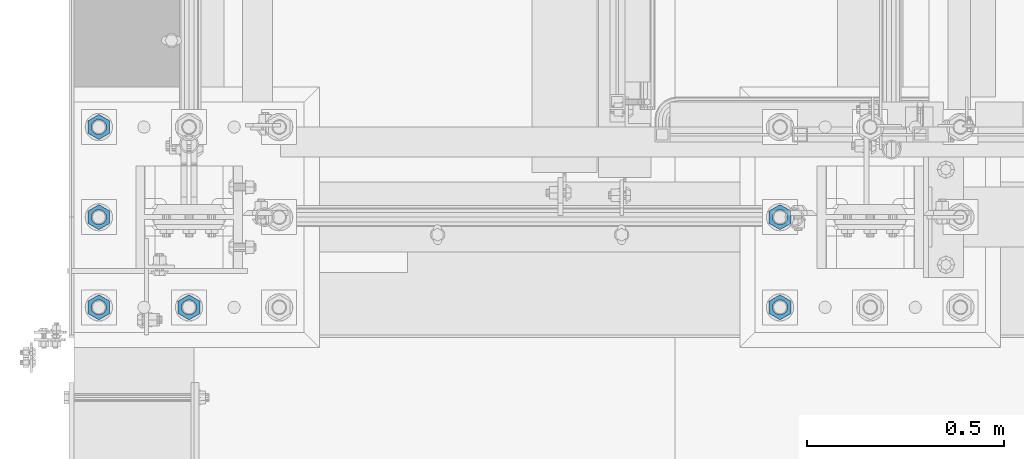
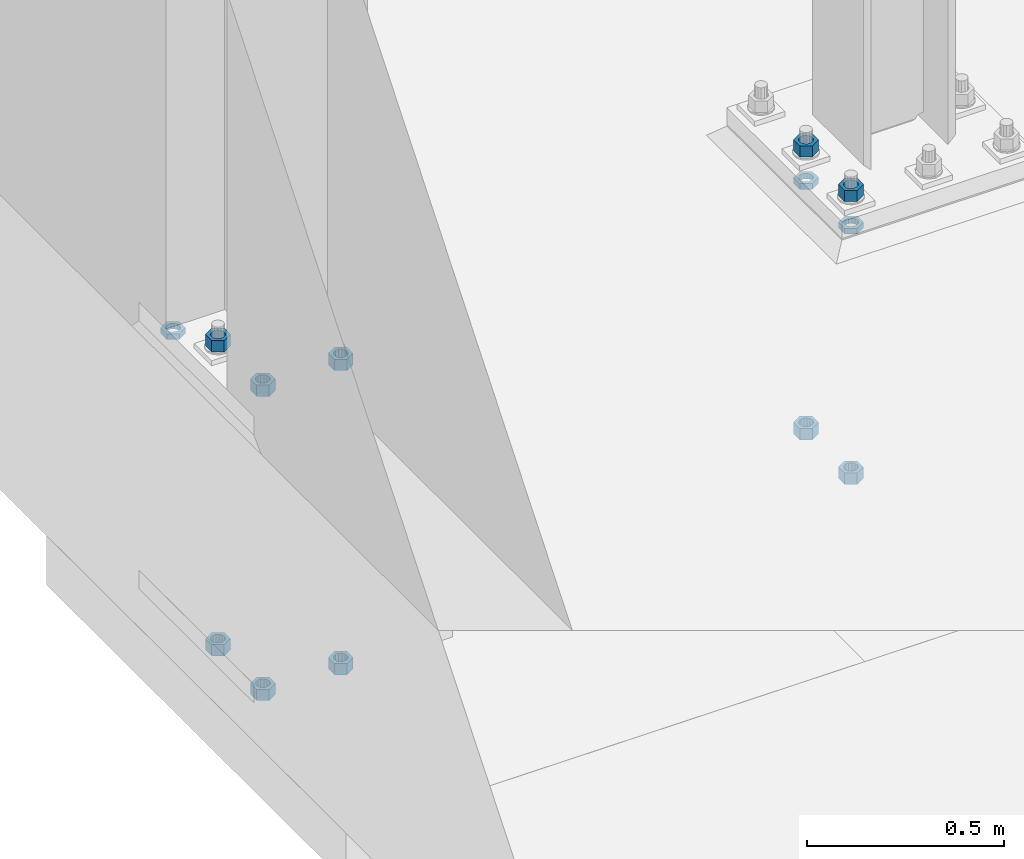
# One storey, part 1382 of 1876: 13 beams, 2 elements without a shape of their own.
"""IFC2X3 building model written with IfcOpenShell, lengths in millimetres."""

from ifc_helpers import new_model, si_unit, frame, origin_with_axes, place, context, subcontext, project, spatial, faceted_brep, material, type_object, element, aggregate, save


model = new_model("IFC2X3")

# Units and contexts
model_context = context("Model", 3, precision=1e-05, world=origin_with_axes())
body_context = subcontext(model_context, "Body", "Model", "MODEL_VIEW")
ifc_project = project(units=[si_unit("LENGTHUNIT", "METRE", prefix="MILLI"), si_unit("AREAUNIT", "SQUARE_METRE"), si_unit("VOLUMEUNIT", "CUBIC_METRE"), si_unit("MASSUNIT", "GRAM", prefix="KILO"), si_unit("TIMEUNIT", "SECOND"), si_unit("PLANEANGLEUNIT", "RADIAN"), si_unit("SOLIDANGLEUNIT", "STERADIAN"), si_unit("THERMODYNAMICTEMPERATUREUNIT", "DEGREE_CELSIUS"), si_unit("LUMINOUSINTENSITYUNIT", "LUMEN")], contexts=[model_context])

# Site, building, storey
site_placement = place(None, origin_with_axes())
site = spatial("IfcSite", under=ifc_project, at=site_placement, CompositionType="ELEMENT")
building_placement = place(site_placement, origin_with_axes())
building = spatial("IfcBuilding", under=site, at=building_placement, Name="Undefined", CompositionType="ELEMENT")
storey_placement = place(building_placement, origin_with_axes())
storey = spatial("IfcBuildingStorey", under=building, at=storey_placement, Name="Undefined", CompositionType="ELEMENT", Elevation=0.0)

# Assembly, beams
assembly_1_placement = place(storey_placement, origin_with_axes())
assembly_1 = element("IfcElementAssembly", 1, at=assembly_1_placement, inside=storey, Name="TEMPLATE", AssemblyPlace="NOTDEFINED", PredefinedType="RIGID_FRAME")
ifc_material = material(Name="STEEL/A563")
beam_type_1 = type_object("IfcBeamType", Name="1-3/8_DIA. HALF_NUT", PredefinedType="NOTDEFINED")
beam_1_placement = place(assembly_1_placement, frame((1498.6, -7112.0, 33.3375), z_axis=(1.0, 0.0, 0.0), x_axis=(0.0, 0.0, -1.0)))
beam_1 = element("IfcBeam", 2, at=beam_1_placement, type_object=beam_type_1, material=ifc_material, Name="NUT", ObjectType="1-3/8_DIA. HALF_NUT", context=body_context, shape_type="Brep", body=[
    faceted_brep([(0.0, -31.75, 0.0), (0.0, -15.8800001144409, -27.5), (17.4625, -15.8800001144409, -27.5), (17.4625, -31.75, 0.0), (0.0, 15.8800001144409, -27.5), (17.4625, 15.8800001144409, -27.5), (0.0, 31.75, 0.0), (17.4625, 31.75, 0.0), (0.0, 15.8800001144409, 27.5), (17.4625, 15.8800001144409, 27.5), (0.0, -15.8800001144409, 27.5), (17.4625, -15.8800001144409, 27.5), (0.0, 0.0, 19.0499999999993), (0.0, 8.2654848991624, 17.1634562461559), (17.4625, 8.2654848991624, 17.1634562461559), (17.4625, 0.0, 19.0499992370605), (0.0, 14.8938891445259, 11.8774802497237), (17.4625, 14.8938891445259, 11.8774802497237), (0.0, 18.5723759832526, 4.2390236220981), (17.4625, 18.5723759832526, 4.2390236220981), (0.0, 18.5723759832526, -4.2390236220981), (17.4625, 18.5723759832526, -4.2390236220981), (0.0, 14.8938891445259, -11.8774802497237), (17.4625, 14.8938891445259, -11.8774802497237), (0.0, 8.2654848991624, -17.1634562461568), (17.4625, 8.2654848991624, -17.1634562461568), (0.0, 0.0, -19.05), (17.4625, 0.0, -19.0499992370605), (0.0, -8.2654848991624, -17.1634562461559), (17.4625, -8.2654848991624, -17.1634562461559), (0.0, -14.8938891445259, -11.8774802497237), (17.4625, -14.8938891445259, -11.8774802497237), (0.0, -18.5723759832526, -4.2390236220981), (17.4625, -18.5723759832526, -4.2390236220981), (0.0, -18.5723759832526, 4.2390236220981), (17.4625, -18.5723759832526, 4.2390236220981), (0.0, -14.8938891445259, 11.8774802497237), (17.4625, -14.8938891445259, 11.8774802497237), (0.0, -8.2654848991624, 17.1634562461568), (17.4625, -8.2654848991624, 17.1634562461568)], [[[0, 1, 2, 3]], [[1, 4, 5, 2]], [[4, 6, 7, 5]], [[6, 8, 9, 7]], [[8, 10, 11, 9]], [[10, 0, 3, 11]], [[12, 13, 14, 15]], [[13, 16, 17, 14]], [[16, 18, 19, 17]], [[18, 20, 21, 19]], [[20, 22, 23, 21]], [[22, 24, 25, 23]], [[24, 26, 27, 25]], [[26, 28, 29, 27]], [[28, 30, 31, 29]], [[30, 32, 33, 31]], [[32, 34, 35, 33]], [[34, 36, 37, 35]], [[36, 38, 39, 37]], [[38, 12, 15, 39]], [[5, 7, 9, 11, 3, 2], [17, 19, 21, 23, 25, 27, 29, 31, 33, 35, 37, 39, 15, 14]], [[10, 8, 6, 4, 1, 0], [38, 36, 34, 32, 30, 28, 26, 24, 22, 20, 18, 16, 13, 12]]]),
])
beam_2_placement = place(assembly_1_placement, frame((1498.6, -7340.6, 33.3375), z_axis=(1.0, 0.0, 0.0), x_axis=(0.0, 0.0, -1.0)))
beam_2 = element("IfcBeam", 3, at=beam_2_placement, type_object=beam_type_1, material=ifc_material, Name="NUT", ObjectType="1-3/8_DIA. HALF_NUT", context=body_context, shape_type="Brep", body=[
    faceted_brep([(0.0, -31.75, 0.0), (0.0, -15.8800001144409, -27.5), (17.4625, -15.8800001144409, -27.5), (17.4625, -31.75, 0.0), (0.0, 15.8800001144409, -27.5), (17.4625, 15.8800001144409, -27.5), (0.0, 31.75, 0.0), (17.4625, 31.75, 0.0), (0.0, 15.8800001144409, 27.5), (17.4625, 15.8800001144409, 27.5), (0.0, -15.8800001144409, 27.5), (17.4625, -15.8800001144409, 27.5), (0.0, 0.0, 19.0499999999993), (0.0, 8.2654848991624, 17.1634562461559), (17.4625, 8.2654848991624, 17.1634562461559), (17.4625, 0.0, 19.0499992370605), (0.0, 14.8938891445259, 11.8774802497237), (17.4625, 14.8938891445259, 11.8774802497237), (0.0, 18.5723759832526, 4.2390236220981), (17.4625, 18.5723759832526, 4.2390236220981), (0.0, 18.5723759832526, -4.2390236220981), (17.4625, 18.5723759832526, -4.2390236220981), (0.0, 14.8938891445259, -11.8774802497237), (17.4625, 14.8938891445259, -11.8774802497237), (0.0, 8.2654848991624, -17.1634562461568), (17.4625, 8.2654848991624, -17.1634562461568), (0.0, 0.0, -19.05), (17.4625, 0.0, -19.0499992370605), (0.0, -8.2654848991624, -17.1634562461559), (17.4625, -8.2654848991624, -17.1634562461559), (0.0, -14.8938891445259, -11.8774802497237), (17.4625, -14.8938891445259, -11.8774802497237), (0.0, -18.5723759832526, -4.2390236220981), (17.4625, -18.5723759832526, -4.2390236220981), (0.0, -18.5723759832526, 4.2390236220981), (17.4625, -18.5723759832526, 4.2390236220981), (0.0, -14.8938891445259, 11.8774802497237), (17.4625, -14.8938891445259, 11.8774802497237), (0.0, -8.2654848991624, 17.1634562461568), (17.4625, -8.2654848991624, 17.1634562461568)], [[[0, 1, 2, 3]], [[1, 4, 5, 2]], [[4, 6, 7, 5]], [[6, 8, 9, 7]], [[8, 10, 11, 9]], [[10, 0, 3, 11]], [[12, 13, 14, 15]], [[13, 16, 17, 14]], [[16, 18, 19, 17]], [[18, 20, 21, 19]], [[20, 22, 23, 21]], [[22, 24, 25, 23]], [[24, 26, 27, 25]], [[26, 28, 29, 27]], [[28, 30, 31, 29]], [[30, 32, 33, 31]], [[32, 34, 35, 33]], [[34, 36, 37, 35]], [[36, 38, 39, 37]], [[38, 12, 15, 39]], [[5, 7, 9, 11, 3, 2], [17, 19, 21, 23, 25, 27, 29, 31, 33, 35, 37, 39, 15, 14]], [[10, 8, 6, 4, 1, 0], [38, 36, 34, 32, 30, 28, 26, 24, 22, 20, 18, 16, 13, 12]]]),
])

# Assembly, beam
assembly_2_placement = place(storey_placement, origin_with_axes())
assembly_2 = element("IfcElementAssembly", 4, at=assembly_2_placement, inside=storey, Name="TEMPLATE", AssemblyPlace="NOTDEFINED", PredefinedType="RIGID_FRAME")
beam_3_placement = place(assembly_2_placement, frame((-228.6, -6883.4, 33.3375), z_axis=(-1.0, 0.0, 0.0), x_axis=(0.0, 0.0, -1.0)))
beam_3 = element("IfcBeam", 5, at=beam_3_placement, type_object=beam_type_1, material=ifc_material, Name="NUT", ObjectType="1-3/8_DIA. HALF_NUT", context=body_context, shape_type="Brep", body=[
    faceted_brep([(0.0, -31.75, 0.0), (0.0, -15.8800001144409, -27.5), (17.4625, -15.8800001144409, -27.5), (17.4625, -31.75, 0.0), (0.0, 15.8800001144409, -27.5), (17.4625, 15.8800001144409, -27.5), (0.0, 31.75, 0.0), (17.4625, 31.75, 0.0), (0.0, 15.8800001144409, 27.5), (17.4625, 15.8800001144409, 27.5), (0.0, -15.8800001144409, 27.5), (17.4625, -15.8800001144409, 27.5), (0.0, 0.0, 19.0499999999993), (0.0, 8.2654848991624, 17.1634562461559), (17.4625, 8.2654848991624, 17.1634562461559), (17.4625, 0.0, 19.0499992370605), (0.0, 14.8938891445259, 11.8774802497237), (17.4625, 14.8938891445259, 11.8774802497237), (0.0, 18.5723759832526, 4.2390236220981), (17.4625, 18.5723759832526, 4.2390236220981), (0.0, 18.5723759832526, -4.2390236220981), (17.4625, 18.5723759832526, -4.2390236220981), (0.0, 14.8938891445259, -11.8774802497237), (17.4625, 14.8938891445259, -11.8774802497237), (0.0, 8.2654848991624, -17.1634562461568), (17.4625, 8.2654848991624, -17.1634562461568), (0.0, 0.0, -19.05), (17.4625, 0.0, -19.0499992370605), (0.0, -8.2654848991624, -17.1634562461559), (17.4625, -8.2654848991624, -17.1634562461559), (0.0, -14.8938891445259, -11.8774802497237), (17.4625, -14.8938891445259, -11.8774802497237), (0.0, -18.5723759832526, -4.2390236220981), (17.4625, -18.5723759832526, -4.2390236220981), (0.0, -18.5723759832526, 4.2390236220981), (17.4625, -18.5723759832526, 4.2390236220981), (0.0, -14.8938891445259, 11.8774802497237), (17.4625, -14.8938891445259, 11.8774802497237), (0.0, -8.2654848991624, 17.1634562461568), (17.4625, -8.2654848991624, 17.1634562461568)], [[[0, 1, 2, 3]], [[1, 4, 5, 2]], [[4, 6, 7, 5]], [[6, 8, 9, 7]], [[8, 10, 11, 9]], [[10, 0, 3, 11]], [[12, 13, 14, 15]], [[13, 16, 17, 14]], [[16, 18, 19, 17]], [[18, 20, 21, 19]], [[20, 22, 23, 21]], [[22, 24, 25, 23]], [[24, 26, 27, 25]], [[26, 28, 29, 27]], [[28, 30, 31, 29]], [[30, 32, 33, 31]], [[32, 34, 35, 33]], [[34, 36, 37, 35]], [[36, 38, 39, 37]], [[38, 12, 15, 39]], [[5, 7, 9, 11, 3, 2], [17, 19, 21, 23, 25, 27, 29, 31, 33, 35, 37, 39, 15, 14]], [[10, 8, 6, 4, 1, 0], [38, 36, 34, 32, 30, 28, 26, 24, 22, 20, 18, 16, 13, 12]]]),
])

# Beam
beam_type_2 = type_object("IfcBeamType", Name="1-3/8_HEAVY_HEX_NUT", PredefinedType="NOTDEFINED")
beam_4_placement = place(assembly_1_placement, frame((1498.60001220703, -7340.6, -727.074998474121), z_axis=(1.0, 0.0, 0.0), x_axis=(0.0, 0.0, -1.0)))
beam_4 = element("IfcBeam", 6, at=beam_4_placement, type_object=beam_type_2, material=ifc_material, Name="NUT", ObjectType="1-3/8_HEAVY_HEX_NUT", context=body_context, shape_type="Brep", body=[
    faceted_brep([(0.0, -31.75, 0.0), (0.0, -15.8800001144409, -27.5), (34.925, -15.8800001144409, -27.5), (34.925, -31.75, 0.0), (0.0, 15.8800001144409, -27.5), (34.925, 15.8800001144409, -27.5), (0.0, 31.75, 0.0), (34.925, 31.75, 0.0), (0.0, 15.8800001144409, 27.5), (34.925, 15.8800001144409, 27.5), (0.0, -15.8800001144409, 27.5), (34.925, -15.8800001144409, 27.5), (0.0, 0.0, 19.0499999999993), (0.0, 8.2654848991624, 17.1634562461559), (34.925, 8.26548489916252, 17.163456246155), (34.925, 0.0, 19.0499992370605), (0.0, 14.8938891445259, 11.8774802497237), (34.925, 14.8938891445259, 11.8774802497246), (0.0, 18.5723759832526, 4.2390236220981), (34.925, 18.5723759832528, 4.23902362209628), (0.0, 18.5723759832526, -4.2390236220981), (34.925, 18.5723759832528, -4.23902362209628), (0.0, 14.8938891445259, -11.8774802497237), (34.925, 14.8938891445259, -11.8774802497246), (0.0, 8.2654848991624, -17.1634562461568), (34.925, 8.26548489916252, -17.163456246155), (0.0, 0.0, -19.05), (34.925, 0.0, -19.0499992370605), (0.0, -8.2654848991624, -17.1634562461559), (34.925, -8.26548489916252, -17.163456246155), (0.0, -14.8938891445259, -11.8774802497237), (34.925, -14.8938891445259, -11.8774802497246), (0.0, -18.5723759832526, -4.2390236220981), (34.925, -18.5723759832528, -4.23902362209628), (0.0, -18.5723759832526, 4.2390236220981), (34.925, -18.5723759832528, 4.23902362209628), (0.0, -14.8938891445259, 11.8774802497237), (34.925, -14.8938891445259, 11.8774802497246), (0.0, -8.2654848991624, 17.1634562461568), (34.925, -8.26548489916252, 17.163456246155)], [[[0, 1, 2, 3]], [[1, 4, 5, 2]], [[4, 6, 7, 5]], [[6, 8, 9, 7]], [[8, 10, 11, 9]], [[10, 0, 3, 11]], [[12, 13, 14, 15]], [[13, 16, 17, 14]], [[16, 18, 19, 17]], [[18, 20, 21, 19]], [[20, 22, 23, 21]], [[22, 24, 25, 23]], [[24, 26, 27, 25]], [[26, 28, 29, 27]], [[28, 30, 31, 29]], [[30, 32, 33, 31]], [[32, 34, 35, 33]], [[34, 36, 37, 35]], [[36, 38, 39, 37]], [[38, 12, 15, 39]], [[5, 7, 9, 11, 3, 2], [17, 19, 21, 23, 25, 27, 29, 31, 33, 35, 37, 39, 15, 14]], [[10, 8, 6, 4, 1, 0], [38, 36, 34, 32, 30, 28, 26, 24, 22, 20, 18, 16, 13, 12]]]),
])

beam_5_placement = place(assembly_1_placement, frame((1498.60001220703, -7112.0, -727.074998474121), z_axis=(1.0, 0.0, 0.0), x_axis=(0.0, 0.0, -1.0)))
beam_5 = element("IfcBeam", 7, at=beam_5_placement, type_object=beam_type_2, material=ifc_material, Name="NUT", ObjectType="1-3/8_HEAVY_HEX_NUT", context=body_context, shape_type="Brep", body=[
    faceted_brep([(0.0, -31.75, 0.0), (0.0, -15.8800001144409, -27.5), (34.925, -15.8800001144409, -27.5), (34.925, -31.75, 0.0), (0.0, 15.8800001144409, -27.5), (34.925, 15.8800001144409, -27.5), (0.0, 31.75, 0.0), (34.925, 31.75, 0.0), (0.0, 15.8800001144409, 27.5), (34.925, 15.8800001144409, 27.5), (0.0, -15.8800001144409, 27.5), (34.925, -15.8800001144409, 27.5), (0.0, 0.0, 19.0499999999993), (0.0, 8.2654848991624, 17.1634562461559), (34.925, 8.26548489916252, 17.163456246155), (34.925, 0.0, 19.0499992370605), (0.0, 14.8938891445259, 11.8774802497237), (34.925, 14.8938891445259, 11.8774802497246), (0.0, 18.5723759832526, 4.2390236220981), (34.925, 18.5723759832528, 4.23902362209628), (0.0, 18.5723759832526, -4.2390236220981), (34.925, 18.5723759832528, -4.23902362209628), (0.0, 14.8938891445259, -11.8774802497237), (34.925, 14.8938891445259, -11.8774802497246), (0.0, 8.2654848991624, -17.1634562461568), (34.925, 8.26548489916252, -17.163456246155), (0.0, 0.0, -19.05), (34.925, 0.0, -19.0499992370605), (0.0, -8.2654848991624, -17.1634562461559), (34.925, -8.26548489916252, -17.163456246155), (0.0, -14.8938891445259, -11.8774802497237), (34.925, -14.8938891445259, -11.8774802497246), (0.0, -18.5723759832526, -4.2390236220981), (34.925, -18.5723759832528, -4.23902362209628), (0.0, -18.5723759832526, 4.2390236220981), (34.925, -18.5723759832528, 4.23902362209628), (0.0, -14.8938891445259, 11.8774802497237), (34.925, -14.8938891445259, 11.8774802497246), (0.0, -8.2654848991624, 17.1634562461568), (34.925, -8.26548489916252, 17.163456246155)], [[[0, 1, 2, 3]], [[1, 4, 5, 2]], [[4, 6, 7, 5]], [[6, 8, 9, 7]], [[8, 10, 11, 9]], [[10, 0, 3, 11]], [[12, 13, 14, 15]], [[13, 16, 17, 14]], [[16, 18, 19, 17]], [[18, 20, 21, 19]], [[20, 22, 23, 21]], [[22, 24, 25, 23]], [[24, 26, 27, 25]], [[26, 28, 29, 27]], [[28, 30, 31, 29]], [[30, 32, 33, 31]], [[32, 34, 35, 33]], [[34, 36, 37, 35]], [[36, 38, 39, 37]], [[38, 12, 15, 39]], [[5, 7, 9, 11, 3, 2], [17, 19, 21, 23, 25, 27, 29, 31, 33, 35, 37, 39, 15, 14]], [[10, 8, 6, 4, 1, 0], [38, 36, 34, 32, 30, 28, 26, 24, 22, 20, 18, 16, 13, 12]]]),
])

beam_6_placement = place(assembly_1_placement, frame((1498.6, -7340.6, 150.8125), z_axis=(1.0, 0.0, 0.0), x_axis=(0.0, 0.0, -1.0)))
beam_6 = element("IfcBeam", 8, at=beam_6_placement, type_object=beam_type_2, material=ifc_material, Name="NUT", ObjectType="1-3/8_HEAVY_HEX_NUT", context=body_context, shape_type="Brep", body=[
    faceted_brep([(0.0, -31.75, 0.0), (0.0, -15.8800001144409, -27.5), (34.925, -15.8800001144409, -27.5), (34.925, -31.75, 0.0), (0.0, 15.8800001144409, -27.5), (34.925, 15.8800001144409, -27.5), (0.0, 31.75, 0.0), (34.925, 31.75, 0.0), (0.0, 15.8800001144409, 27.5), (34.925, 15.8800001144409, 27.5), (0.0, -15.8800001144409, 27.5), (34.925, -15.8800001144409, 27.5), (0.0, 0.0, 19.0499999999993), (0.0, 8.2654848991624, 17.1634562461559), (34.925, 8.26548489916252, 17.163456246155), (34.925, 0.0, 19.0499992370605), (0.0, 14.8938891445259, 11.8774802497237), (34.925, 14.8938891445259, 11.8774802497246), (0.0, 18.5723759832526, 4.2390236220981), (34.925, 18.5723759832528, 4.23902362209628), (0.0, 18.5723759832526, -4.2390236220981), (34.925, 18.5723759832528, -4.23902362209628), (0.0, 14.8938891445259, -11.8774802497237), (34.925, 14.8938891445259, -11.8774802497246), (0.0, 8.2654848991624, -17.1634562461568), (34.925, 8.26548489916252, -17.163456246155), (0.0, 0.0, -19.05), (34.925, 0.0, -19.0499992370605), (0.0, -8.2654848991624, -17.1634562461559), (34.925, -8.26548489916252, -17.163456246155), (0.0, -14.8938891445259, -11.8774802497237), (34.925, -14.8938891445259, -11.8774802497246), (0.0, -18.5723759832526, -4.2390236220981), (34.925, -18.5723759832528, -4.23902362209628), (0.0, -18.5723759832526, 4.2390236220981), (34.925, -18.5723759832528, 4.23902362209628), (0.0, -14.8938891445259, 11.8774802497237), (34.925, -14.8938891445259, 11.8774802497246), (0.0, -8.2654848991624, 17.1634562461568), (34.925, -8.26548489916252, 17.163456246155)], [[[0, 1, 2, 3]], [[1, 4, 5, 2]], [[4, 6, 7, 5]], [[6, 8, 9, 7]], [[8, 10, 11, 9]], [[10, 0, 3, 11]], [[12, 13, 14, 15]], [[13, 16, 17, 14]], [[16, 18, 19, 17]], [[18, 20, 21, 19]], [[20, 22, 23, 21]], [[22, 24, 25, 23]], [[24, 26, 27, 25]], [[26, 28, 29, 27]], [[28, 30, 31, 29]], [[30, 32, 33, 31]], [[32, 34, 35, 33]], [[34, 36, 37, 35]], [[36, 38, 39, 37]], [[38, 12, 15, 39]], [[5, 7, 9, 11, 3, 2], [17, 19, 21, 23, 25, 27, 29, 31, 33, 35, 37, 39, 15, 14]], [[10, 8, 6, 4, 1, 0], [38, 36, 34, 32, 30, 28, 26, 24, 22, 20, 18, 16, 13, 12]]]),
])

beam_7_placement = place(assembly_1_placement, frame((1498.6, -7112.0, 150.8125), z_axis=(1.0, 0.0, 0.0), x_axis=(0.0, 0.0, -1.0)))
beam_7 = element("IfcBeam", 9, at=beam_7_placement, type_object=beam_type_2, material=ifc_material, Name="NUT", ObjectType="1-3/8_HEAVY_HEX_NUT", context=body_context, shape_type="Brep", body=[
    faceted_brep([(0.0, -31.75, 0.0), (0.0, -15.8800001144409, -27.5), (34.925, -15.8800001144409, -27.5), (34.925, -31.75, 0.0), (0.0, 15.8800001144409, -27.5), (34.925, 15.8800001144409, -27.5), (0.0, 31.75, 0.0), (34.925, 31.75, 0.0), (0.0, 15.8800001144409, 27.5), (34.925, 15.8800001144409, 27.5), (0.0, -15.8800001144409, 27.5), (34.925, -15.8800001144409, 27.5), (0.0, 0.0, 19.0499999999993), (0.0, 8.2654848991624, 17.1634562461559), (34.925, 8.26548489916252, 17.163456246155), (34.925, 0.0, 19.0499992370605), (0.0, 14.8938891445259, 11.8774802497237), (34.925, 14.8938891445259, 11.8774802497246), (0.0, 18.5723759832526, 4.2390236220981), (34.925, 18.5723759832528, 4.23902362209628), (0.0, 18.5723759832526, -4.2390236220981), (34.925, 18.5723759832528, -4.23902362209628), (0.0, 14.8938891445259, -11.8774802497237), (34.925, 14.8938891445259, -11.8774802497246), (0.0, 8.2654848991624, -17.1634562461568), (34.925, 8.26548489916252, -17.163456246155), (0.0, 0.0, -19.05), (34.925, 0.0, -19.0499992370605), (0.0, -8.2654848991624, -17.1634562461559), (34.925, -8.26548489916252, -17.163456246155), (0.0, -14.8938891445259, -11.8774802497237), (34.925, -14.8938891445259, -11.8774802497246), (0.0, -18.5723759832526, -4.2390236220981), (34.925, -18.5723759832528, -4.23902362209628), (0.0, -18.5723759832526, 4.2390236220981), (34.925, -18.5723759832528, 4.23902362209628), (0.0, -14.8938891445259, 11.8774802497237), (34.925, -14.8938891445259, 11.8774802497246), (0.0, -8.2654848991624, 17.1634562461568), (34.925, -8.26548489916252, 17.163456246155)], [[[0, 1, 2, 3]], [[1, 4, 5, 2]], [[4, 6, 7, 5]], [[6, 8, 9, 7]], [[8, 10, 11, 9]], [[10, 0, 3, 11]], [[12, 13, 14, 15]], [[13, 16, 17, 14]], [[16, 18, 19, 17]], [[18, 20, 21, 19]], [[20, 22, 23, 21]], [[22, 24, 25, 23]], [[24, 26, 27, 25]], [[26, 28, 29, 27]], [[28, 30, 31, 29]], [[30, 32, 33, 31]], [[32, 34, 35, 33]], [[34, 36, 37, 35]], [[36, 38, 39, 37]], [[38, 12, 15, 39]], [[5, 7, 9, 11, 3, 2], [17, 19, 21, 23, 25, 27, 29, 31, 33, 35, 37, 39, 15, 14]], [[10, 8, 6, 4, 1, 0], [38, 36, 34, 32, 30, 28, 26, 24, 22, 20, 18, 16, 13, 12]]]),
])

aggregate(assembly_1, [beam_1, beam_2, beam_4, beam_5, beam_6, beam_7])

beam_8_placement = place(assembly_2_placement, frame((-1.13686837721616e-13, -7340.6, 150.8125), z_axis=(1.0, 0.0, 0.0), x_axis=(0.0, 0.0, -1.0)))
beam_8 = element("IfcBeam", 10, at=beam_8_placement, type_object=beam_type_2, material=ifc_material, Name="NUT", ObjectType="1-3/8_HEAVY_HEX_NUT", context=body_context, shape_type="Brep", body=[
    faceted_brep([(0.0, -31.75, 0.0), (0.0, -15.8800001144409, -27.5), (34.925, -15.8800001144409, -27.5), (34.925, -31.75, 0.0), (0.0, 15.8800001144409, -27.5), (34.925, 15.8800001144409, -27.5), (0.0, 31.75, 0.0), (34.925, 31.75, 0.0), (0.0, 15.8800001144409, 27.5), (34.925, 15.8800001144409, 27.5), (0.0, -15.8800001144409, 27.5), (34.925, -15.8800001144409, 27.5), (0.0, 0.0, 19.0499999999993), (0.0, 8.2654848991624, 17.1634562461559), (34.925, 8.26548489916252, 17.163456246155), (34.925, 0.0, 19.0499992370605), (0.0, 14.8938891445259, 11.8774802497237), (34.925, 14.8938891445259, 11.8774802497246), (0.0, 18.5723759832526, 4.2390236220981), (34.925, 18.5723759832528, 4.23902362209628), (0.0, 18.5723759832526, -4.2390236220981), (34.925, 18.5723759832528, -4.23902362209628), (0.0, 14.8938891445259, -11.8774802497237), (34.925, 14.8938891445259, -11.8774802497246), (0.0, 8.2654848991624, -17.1634562461568), (34.925, 8.26548489916252, -17.163456246155), (0.0, 0.0, -19.05), (34.925, 0.0, -19.0499992370605), (0.0, -8.2654848991624, -17.1634562461559), (34.925, -8.26548489916252, -17.163456246155), (0.0, -14.8938891445259, -11.8774802497237), (34.925, -14.8938891445259, -11.8774802497246), (0.0, -18.5723759832526, -4.2390236220981), (34.925, -18.5723759832528, -4.23902362209628), (0.0, -18.5723759832526, 4.2390236220981), (34.925, -18.5723759832528, 4.23902362209628), (0.0, -14.8938891445259, 11.8774802497237), (34.925, -14.8938891445259, 11.8774802497246), (0.0, -8.2654848991624, 17.1634562461568), (34.925, -8.26548489916252, 17.163456246155)], [[[0, 1, 2, 3]], [[1, 4, 5, 2]], [[4, 6, 7, 5]], [[6, 8, 9, 7]], [[8, 10, 11, 9]], [[10, 0, 3, 11]], [[12, 13, 14, 15]], [[13, 16, 17, 14]], [[16, 18, 19, 17]], [[18, 20, 21, 19]], [[20, 22, 23, 21]], [[22, 24, 25, 23]], [[24, 26, 27, 25]], [[26, 28, 29, 27]], [[28, 30, 31, 29]], [[30, 32, 33, 31]], [[32, 34, 35, 33]], [[34, 36, 37, 35]], [[36, 38, 39, 37]], [[38, 12, 15, 39]], [[5, 7, 9, 11, 3, 2], [17, 19, 21, 23, 25, 27, 29, 31, 33, 35, 37, 39, 15, 14]], [[10, 8, 6, 4, 1, 0], [38, 36, 34, 32, 30, 28, 26, 24, 22, 20, 18, 16, 13, 12]]]),
])

beam_9_placement = place(assembly_2_placement, frame((-1.13686837721616e-13, -7340.6, -793.75), z_axis=(1.0, 0.0, 0.0), x_axis=(0.0, 0.0, -1.0)))
beam_9 = element("IfcBeam", 11, at=beam_9_placement, type_object=beam_type_2, material=ifc_material, Name="NUT", ObjectType="1-3/8_HEAVY_HEX_NUT", context=body_context, shape_type="Brep", body=[
    faceted_brep([(0.0, -31.75, 0.0), (0.0, -15.8800001144409, -27.5), (34.925, -15.8800001144409, -27.5), (34.925, -31.75, 0.0), (0.0, 15.8800001144409, -27.5), (34.925, 15.8800001144409, -27.5), (0.0, 31.75, 0.0), (34.925, 31.75, 0.0), (0.0, 15.8800001144409, 27.5), (34.925, 15.8800001144409, 27.5), (0.0, -15.8800001144409, 27.5), (34.925, -15.8800001144409, 27.5), (0.0, 0.0, 19.0499999999993), (0.0, 8.2654848991624, 17.1634562461559), (34.925, 8.26548489916252, 17.163456246155), (34.925, 0.0, 19.0499992370605), (0.0, 14.8938891445259, 11.8774802497237), (34.925, 14.8938891445259, 11.8774802497246), (0.0, 18.5723759832526, 4.2390236220981), (34.925, 18.5723759832528, 4.23902362209628), (0.0, 18.5723759832526, -4.2390236220981), (34.925, 18.5723759832528, -4.23902362209628), (0.0, 14.8938891445259, -11.8774802497237), (34.925, 14.8938891445259, -11.8774802497246), (0.0, 8.2654848991624, -17.1634562461568), (34.925, 8.26548489916252, -17.163456246155), (0.0, 0.0, -19.05), (34.925, 0.0, -19.0499992370605), (0.0, -8.2654848991624, -17.1634562461559), (34.925, -8.26548489916252, -17.163456246155), (0.0, -14.8938891445259, -11.8774802497237), (34.925, -14.8938891445259, -11.8774802497246), (0.0, -18.5723759832526, -4.2390236220981), (34.925, -18.5723759832528, -4.23902362209628), (0.0, -18.5723759832526, 4.2390236220981), (34.925, -18.5723759832528, 4.23902362209628), (0.0, -14.8938891445259, 11.8774802497237), (34.925, -14.8938891445259, 11.8774802497246), (0.0, -8.2654848991624, 17.1634562461568), (34.925, -8.26548489916252, 17.163456246155)], [[[0, 1, 2, 3]], [[1, 4, 5, 2]], [[4, 6, 7, 5]], [[6, 8, 9, 7]], [[8, 10, 11, 9]], [[10, 0, 3, 11]], [[12, 13, 14, 15]], [[13, 16, 17, 14]], [[16, 18, 19, 17]], [[18, 20, 21, 19]], [[20, 22, 23, 21]], [[22, 24, 25, 23]], [[24, 26, 27, 25]], [[26, 28, 29, 27]], [[28, 30, 31, 29]], [[30, 32, 33, 31]], [[32, 34, 35, 33]], [[34, 36, 37, 35]], [[36, 38, 39, 37]], [[38, 12, 15, 39]], [[5, 7, 9, 11, 3, 2], [17, 19, 21, 23, 25, 27, 29, 31, 33, 35, 37, 39, 15, 14]], [[10, 8, 6, 4, 1, 0], [38, 36, 34, 32, 30, 28, 26, 24, 22, 20, 18, 16, 13, 12]]]),
])

beam_10_placement = place(assembly_2_placement, frame((-228.6, -7340.6, 150.8125), z_axis=(1.0, 0.0, 0.0), x_axis=(0.0, 0.0, -1.0)))
beam_10 = element("IfcBeam", 12, at=beam_10_placement, type_object=beam_type_2, material=ifc_material, Name="NUT", ObjectType="1-3/8_HEAVY_HEX_NUT", context=body_context, shape_type="Brep", body=[
    faceted_brep([(0.0, -31.75, 0.0), (0.0, -15.8800001144409, -27.5), (34.925, -15.8800001144409, -27.5), (34.925, -31.75, 0.0), (0.0, 15.8800001144409, -27.5), (34.925, 15.8800001144409, -27.5), (0.0, 31.75, 0.0), (34.925, 31.75, 0.0), (0.0, 15.8800001144409, 27.5), (34.925, 15.8800001144409, 27.5), (0.0, -15.8800001144409, 27.5), (34.925, -15.8800001144409, 27.5), (0.0, 0.0, 19.0499999999993), (0.0, 8.2654848991624, 17.1634562461559), (34.925, 8.26548489916252, 17.163456246155), (34.925, 0.0, 19.0499992370605), (0.0, 14.8938891445259, 11.8774802497237), (34.925, 14.8938891445259, 11.8774802497246), (0.0, 18.5723759832526, 4.2390236220981), (34.925, 18.5723759832528, 4.23902362209628), (0.0, 18.5723759832526, -4.2390236220981), (34.925, 18.5723759832528, -4.23902362209628), (0.0, 14.8938891445259, -11.8774802497237), (34.925, 14.8938891445259, -11.8774802497246), (0.0, 8.2654848991624, -17.1634562461568), (34.925, 8.26548489916252, -17.163456246155), (0.0, 0.0, -19.05), (34.925, 0.0, -19.0499992370605), (0.0, -8.2654848991624, -17.1634562461559), (34.925, -8.26548489916252, -17.163456246155), (0.0, -14.8938891445259, -11.8774802497237), (34.925, -14.8938891445259, -11.8774802497246), (0.0, -18.5723759832526, -4.2390236220981), (34.925, -18.5723759832528, -4.23902362209628), (0.0, -18.5723759832526, 4.2390236220981), (34.925, -18.5723759832528, 4.23902362209628), (0.0, -14.8938891445259, 11.8774802497237), (34.925, -14.8938891445259, 11.8774802497246), (0.0, -8.2654848991624, 17.1634562461568), (34.925, -8.26548489916252, 17.163456246155)], [[[0, 1, 2, 3]], [[1, 4, 5, 2]], [[4, 6, 7, 5]], [[6, 8, 9, 7]], [[8, 10, 11, 9]], [[10, 0, 3, 11]], [[12, 13, 14, 15]], [[13, 16, 17, 14]], [[16, 18, 19, 17]], [[18, 20, 21, 19]], [[20, 22, 23, 21]], [[22, 24, 25, 23]], [[24, 26, 27, 25]], [[26, 28, 29, 27]], [[28, 30, 31, 29]], [[30, 32, 33, 31]], [[32, 34, 35, 33]], [[34, 36, 37, 35]], [[36, 38, 39, 37]], [[38, 12, 15, 39]], [[5, 7, 9, 11, 3, 2], [17, 19, 21, 23, 25, 27, 29, 31, 33, 35, 37, 39, 15, 14]], [[10, 8, 6, 4, 1, 0], [38, 36, 34, 32, 30, 28, 26, 24, 22, 20, 18, 16, 13, 12]]]),
])

beam_11_placement = place(assembly_2_placement, frame((-228.6, -7340.6, -793.75), z_axis=(1.0, 0.0, 0.0), x_axis=(0.0, 0.0, -1.0)))
beam_11 = element("IfcBeam", 13, at=beam_11_placement, type_object=beam_type_2, material=ifc_material, Name="NUT", ObjectType="1-3/8_HEAVY_HEX_NUT", context=body_context, shape_type="Brep", body=[
    faceted_brep([(0.0, -31.75, 0.0), (0.0, -15.8800001144409, -27.5), (34.925, -15.8800001144409, -27.5), (34.925, -31.75, 0.0), (0.0, 15.8800001144409, -27.5), (34.925, 15.8800001144409, -27.5), (0.0, 31.75, 0.0), (34.925, 31.75, 0.0), (0.0, 15.8800001144409, 27.5), (34.925, 15.8800001144409, 27.5), (0.0, -15.8800001144409, 27.5), (34.925, -15.8800001144409, 27.5), (0.0, 0.0, 19.0499999999993), (0.0, 8.2654848991624, 17.1634562461559), (34.925, 8.26548489916252, 17.163456246155), (34.925, 0.0, 19.0499992370605), (0.0, 14.8938891445259, 11.8774802497237), (34.925, 14.8938891445259, 11.8774802497246), (0.0, 18.5723759832526, 4.2390236220981), (34.925, 18.5723759832528, 4.23902362209628), (0.0, 18.5723759832526, -4.2390236220981), (34.925, 18.5723759832528, -4.23902362209628), (0.0, 14.8938891445259, -11.8774802497237), (34.925, 14.8938891445259, -11.8774802497246), (0.0, 8.2654848991624, -17.1634562461568), (34.925, 8.26548489916252, -17.163456246155), (0.0, 0.0, -19.05), (34.925, 0.0, -19.0499992370605), (0.0, -8.2654848991624, -17.1634562461559), (34.925, -8.26548489916252, -17.163456246155), (0.0, -14.8938891445259, -11.8774802497237), (34.925, -14.8938891445259, -11.8774802497246), (0.0, -18.5723759832526, -4.2390236220981), (34.925, -18.5723759832528, -4.23902362209628), (0.0, -18.5723759832526, 4.2390236220981), (34.925, -18.5723759832528, 4.23902362209628), (0.0, -14.8938891445259, 11.8774802497237), (34.925, -14.8938891445259, 11.8774802497246), (0.0, -8.2654848991624, 17.1634562461568), (34.925, -8.26548489916252, 17.163456246155)], [[[0, 1, 2, 3]], [[1, 4, 5, 2]], [[4, 6, 7, 5]], [[6, 8, 9, 7]], [[8, 10, 11, 9]], [[10, 0, 3, 11]], [[12, 13, 14, 15]], [[13, 16, 17, 14]], [[16, 18, 19, 17]], [[18, 20, 21, 19]], [[20, 22, 23, 21]], [[22, 24, 25, 23]], [[24, 26, 27, 25]], [[26, 28, 29, 27]], [[28, 30, 31, 29]], [[30, 32, 33, 31]], [[32, 34, 35, 33]], [[34, 36, 37, 35]], [[36, 38, 39, 37]], [[38, 12, 15, 39]], [[5, 7, 9, 11, 3, 2], [17, 19, 21, 23, 25, 27, 29, 31, 33, 35, 37, 39, 15, 14]], [[10, 8, 6, 4, 1, 0], [38, 36, 34, 32, 30, 28, 26, 24, 22, 20, 18, 16, 13, 12]]]),
])

beam_12_placement = place(assembly_2_placement, frame((-228.6, -7112.0, 150.8125), z_axis=(1.0, 0.0, 0.0), x_axis=(0.0, 0.0, -1.0)))
beam_12 = element("IfcBeam", 14, at=beam_12_placement, type_object=beam_type_2, material=ifc_material, Name="NUT", ObjectType="1-3/8_HEAVY_HEX_NUT", context=body_context, shape_type="Brep", body=[
    faceted_brep([(0.0, -31.75, 0.0), (0.0, -15.8800001144409, -27.5), (34.925, -15.8800001144409, -27.5), (34.925, -31.75, 0.0), (0.0, 15.8800001144409, -27.5), (34.925, 15.8800001144409, -27.5), (0.0, 31.75, 0.0), (34.925, 31.75, 0.0), (0.0, 15.8800001144409, 27.5), (34.925, 15.8800001144409, 27.5), (0.0, -15.8800001144409, 27.5), (34.925, -15.8800001144409, 27.5), (0.0, 0.0, 19.0499999999993), (0.0, 8.2654848991624, 17.1634562461559), (34.925, 8.26548489916252, 17.163456246155), (34.925, 0.0, 19.0499992370605), (0.0, 14.8938891445259, 11.8774802497237), (34.925, 14.8938891445259, 11.8774802497246), (0.0, 18.5723759832526, 4.2390236220981), (34.925, 18.5723759832528, 4.23902362209628), (0.0, 18.5723759832526, -4.2390236220981), (34.925, 18.5723759832528, -4.23902362209628), (0.0, 14.8938891445259, -11.8774802497237), (34.925, 14.8938891445259, -11.8774802497246), (0.0, 8.2654848991624, -17.1634562461568), (34.925, 8.26548489916252, -17.163456246155), (0.0, 0.0, -19.05), (34.925, 0.0, -19.0499992370605), (0.0, -8.2654848991624, -17.1634562461559), (34.925, -8.26548489916252, -17.163456246155), (0.0, -14.8938891445259, -11.8774802497237), (34.925, -14.8938891445259, -11.8774802497246), (0.0, -18.5723759832526, -4.2390236220981), (34.925, -18.5723759832528, -4.23902362209628), (0.0, -18.5723759832526, 4.2390236220981), (34.925, -18.5723759832528, 4.23902362209628), (0.0, -14.8938891445259, 11.8774802497237), (34.925, -14.8938891445259, 11.8774802497246), (0.0, -8.2654848991624, 17.1634562461568), (34.925, -8.26548489916252, 17.163456246155)], [[[0, 1, 2, 3]], [[1, 4, 5, 2]], [[4, 6, 7, 5]], [[6, 8, 9, 7]], [[8, 10, 11, 9]], [[10, 0, 3, 11]], [[12, 13, 14, 15]], [[13, 16, 17, 14]], [[16, 18, 19, 17]], [[18, 20, 21, 19]], [[20, 22, 23, 21]], [[22, 24, 25, 23]], [[24, 26, 27, 25]], [[26, 28, 29, 27]], [[28, 30, 31, 29]], [[30, 32, 33, 31]], [[32, 34, 35, 33]], [[34, 36, 37, 35]], [[36, 38, 39, 37]], [[38, 12, 15, 39]], [[5, 7, 9, 11, 3, 2], [17, 19, 21, 23, 25, 27, 29, 31, 33, 35, 37, 39, 15, 14]], [[10, 8, 6, 4, 1, 0], [38, 36, 34, 32, 30, 28, 26, 24, 22, 20, 18, 16, 13, 12]]]),
])

beam_13_placement = place(assembly_2_placement, frame((-228.6, -7112.0, -793.75), z_axis=(1.0, 0.0, 0.0), x_axis=(0.0, 0.0, -1.0)))
beam_13 = element("IfcBeam", 15, at=beam_13_placement, type_object=beam_type_2, material=ifc_material, Name="NUT", ObjectType="1-3/8_HEAVY_HEX_NUT", context=body_context, shape_type="Brep", body=[
    faceted_brep([(0.0, -31.75, 0.0), (0.0, -15.8800001144409, -27.5), (34.925, -15.8800001144409, -27.5), (34.925, -31.75, 0.0), (0.0, 15.8800001144409, -27.5), (34.925, 15.8800001144409, -27.5), (0.0, 31.75, 0.0), (34.925, 31.75, 0.0), (0.0, 15.8800001144409, 27.5), (34.925, 15.8800001144409, 27.5), (0.0, -15.8800001144409, 27.5), (34.925, -15.8800001144409, 27.5), (0.0, 0.0, 19.0499999999993), (0.0, 8.2654848991624, 17.1634562461559), (34.925, 8.26548489916252, 17.163456246155), (34.925, 0.0, 19.0499992370605), (0.0, 14.8938891445259, 11.8774802497237), (34.925, 14.8938891445259, 11.8774802497246), (0.0, 18.5723759832526, 4.2390236220981), (34.925, 18.5723759832528, 4.23902362209628), (0.0, 18.5723759832526, -4.2390236220981), (34.925, 18.5723759832528, -4.23902362209628), (0.0, 14.8938891445259, -11.8774802497237), (34.925, 14.8938891445259, -11.8774802497246), (0.0, 8.2654848991624, -17.1634562461568), (34.925, 8.26548489916252, -17.163456246155), (0.0, 0.0, -19.05), (34.925, 0.0, -19.0499992370605), (0.0, -8.2654848991624, -17.1634562461559), (34.925, -8.26548489916252, -17.163456246155), (0.0, -14.8938891445259, -11.8774802497237), (34.925, -14.8938891445259, -11.8774802497246), (0.0, -18.5723759832526, -4.2390236220981), (34.925, -18.5723759832528, -4.23902362209628), (0.0, -18.5723759832526, 4.2390236220981), (34.925, -18.5723759832528, 4.23902362209628), (0.0, -14.8938891445259, 11.8774802497237), (34.925, -14.8938891445259, 11.8774802497246), (0.0, -8.2654848991624, 17.1634562461568), (34.925, -8.26548489916252, 17.163456246155)], [[[0, 1, 2, 3]], [[1, 4, 5, 2]], [[4, 6, 7, 5]], [[6, 8, 9, 7]], [[8, 10, 11, 9]], [[10, 0, 3, 11]], [[12, 13, 14, 15]], [[13, 16, 17, 14]], [[16, 18, 19, 17]], [[18, 20, 21, 19]], [[20, 22, 23, 21]], [[22, 24, 25, 23]], [[24, 26, 27, 25]], [[26, 28, 29, 27]], [[28, 30, 31, 29]], [[30, 32, 33, 31]], [[32, 34, 35, 33]], [[34, 36, 37, 35]], [[36, 38, 39, 37]], [[38, 12, 15, 39]], [[5, 7, 9, 11, 3, 2], [17, 19, 21, 23, 25, 27, 29, 31, 33, 35, 37, 39, 15, 14]], [[10, 8, 6, 4, 1, 0], [38, 36, 34, 32, 30, 28, 26, 24, 22, 20, 18, 16, 13, 12]]]),
])

aggregate(assembly_2, [beam_3, beam_8, beam_9, beam_10, beam_11, beam_12, beam_13])

save(model, "model.ifc")
